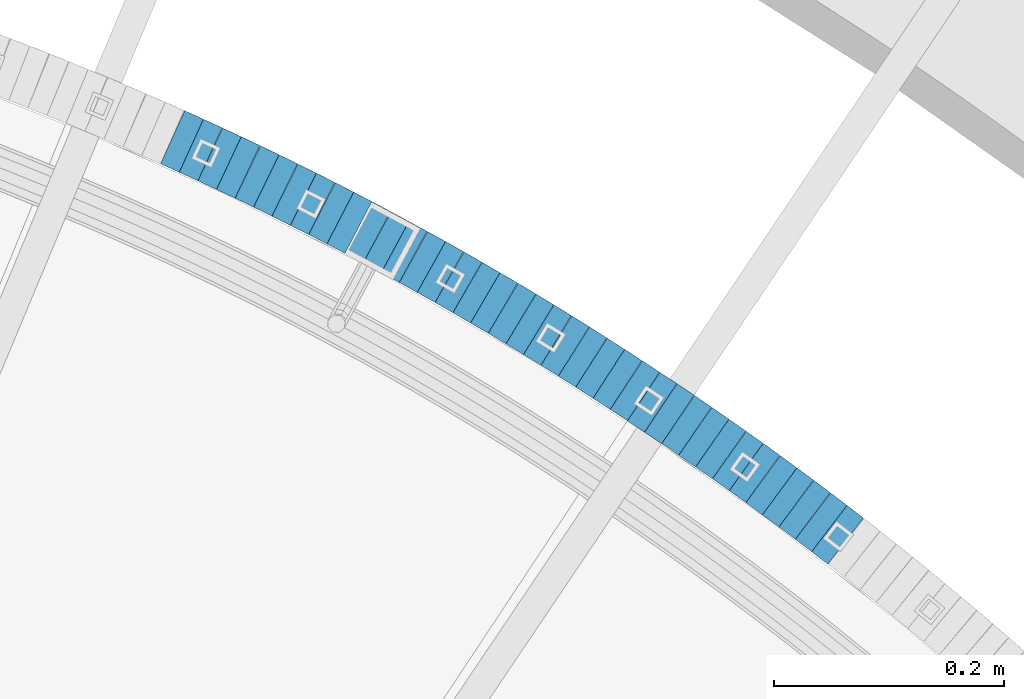
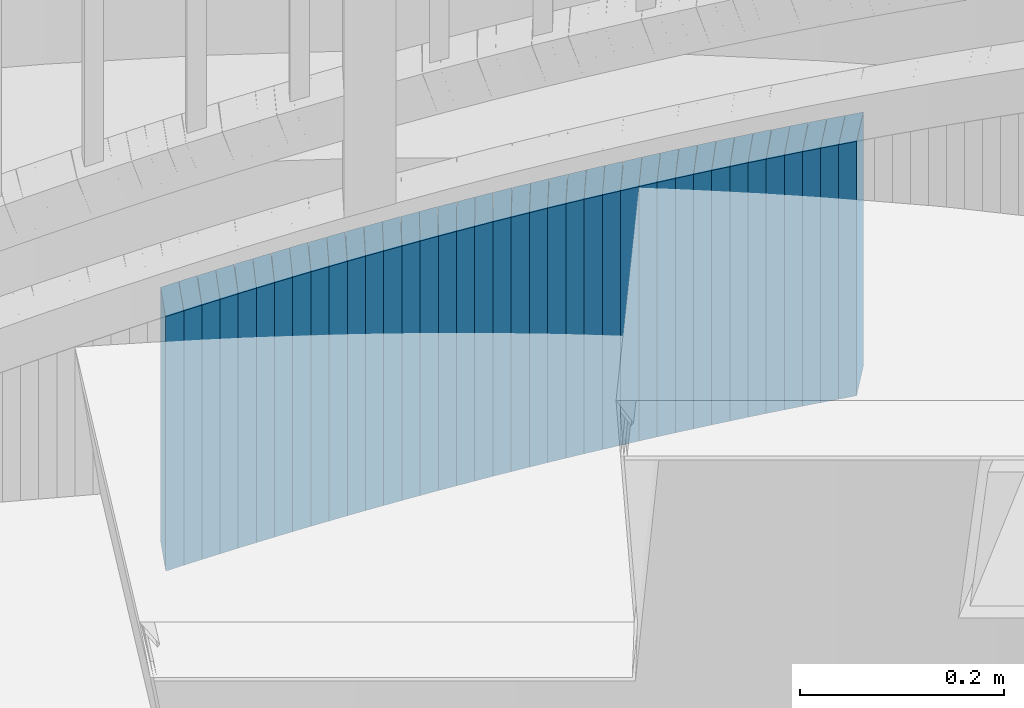
# One storey, part 913 of 975: 38 plates.
"""IFC2X3 building model written with IfcOpenShell, lengths in millimetres."""

from ifc_helpers import new_model, si_unit, frame, origin_with_axes, place, context, subcontext, project, spatial, faceted_brep, material, type_object, element, save


model = new_model("IFC2X3")

# Units and contexts
model_context = context("Model", 3, precision=1e-05, world=origin_with_axes())
body_context = subcontext(model_context, "Body", "Model", "MODEL_VIEW")
ifc_project = project(units=[si_unit("LENGTHUNIT", "METRE", prefix="MILLI"), si_unit("AREAUNIT", "SQUARE_METRE"), si_unit("VOLUMEUNIT", "CUBIC_METRE"), si_unit("MASSUNIT", "GRAM", prefix="KILO"), si_unit("TIMEUNIT", "SECOND"), si_unit("PLANEANGLEUNIT", "RADIAN"), si_unit("SOLIDANGLEUNIT", "STERADIAN"), si_unit("THERMODYNAMICTEMPERATUREUNIT", "DEGREE_CELSIUS"), si_unit("LUMINOUSINTENSITYUNIT", "LUMEN")], contexts=[model_context])

# Site, building, storey
site_placement = place(None, origin_with_axes())
site = spatial("IfcSite", under=ifc_project, at=site_placement, CompositionType="ELEMENT")
building_placement = place(site_placement, origin_with_axes())
building = spatial("IfcBuilding", under=site, at=building_placement, Name="Undefined", CompositionType="ELEMENT")
storey_placement = place(building_placement, origin_with_axes())
storey = spatial("IfcBuildingStorey", under=building, at=storey_placement, Name="Undefined", CompositionType="ELEMENT", Elevation=0.0)

# Plates
ifc_material = material(Name="STEEL/A36")
plate_type = type_object("IfcPlateType", PredefinedType="NOTDEFINED")
plate_1_placement = place(storey_placement, frame((36480.3631997308, 5682.42898795321, 1663.29999999174), z_axis=(0.793246576330856, -0.608900541253968, 0.0), x_axis=(0.0, 0.0, -1.0)))
element("IfcPlate", 1, at=plate_1_placement, inside=storey, type_object=plate_type, material=ifc_material, Name="WALL", context=body_context, shape_type="Brep", body=[
    faceted_brep([(0.0, -25.3999999999724, -1.81898940354586e-11), (-5.80000019073486, -25.3999999999614, 17.8966484070224), (-5.80000019073486, 25.3999999999105, 17.896648406906), (0.0, 25.3999999999869, 1.45519152283669e-11), (299.0, -25.3999999999614, 17.8966484070224), (299.0, 25.3999999999105, 17.896648406906), (304.799987792969, -25.3999999999724, -1.81898940354586e-11), (304.799987792969, 25.3999999999869, 1.45519152283669e-11)], [[[0, 1, 2, 3]], [[1, 4, 5, 2]], [[4, 6, 7, 5]], [[6, 0, 3, 7]], [[5, 7, 3, 2]], [[6, 4, 1, 0]]]),
])
plate_2_placement = place(storey_placement, frame((36466.0734597563, 5693.29755634309, 1657.59999999174), z_axis=(0.795946119300868, -0.605367471185798, -2.1885171008762e-11), x_axis=(0.0, 0.0, -1.0)))
element("IfcPlate", 2, at=plate_2_placement, inside=storey, type_object=plate_type, material=ifc_material, Name="WALL", context=body_context, shape_type="Brep", body=[
    faceted_brep([(0.0, -25.3999999999724, -1.81898940354586e-11), (-5.69999980926514, -25.3999999999614, 17.8370399475461), (-5.69999980926514, 25.4000000000487, 17.8370399475571), (0.0, 25.3999999999869, 1.45519152283669e-11), (299.100006103516, -25.3999999999614, 17.8370399475461), (299.100006103516, 25.4000000000487, 17.8370399475571), (304.799987792969, -25.3999999999724, -1.81898940354586e-11), (304.799987792969, 25.3999999999869, 1.45519152283669e-11)], [[[0, 1, 2, 3]], [[1, 4, 5, 2]], [[4, 6, 7, 5]], [[6, 0, 3, 7]], [[5, 7, 3, 2]], [[6, 4, 1, 0]]]),
])
plate_3_placement = place(storey_placement, frame((36451.6143616831, 5704.11757822177, 1651.89999999174), z_axis=(0.800671390161603, -0.59910376812092, 0.0), x_axis=(0.0, 0.0, -1.0)))
element("IfcPlate", 3, at=plate_3_placement, inside=storey, type_object=plate_type, material=ifc_material, Name="WALL", context=body_context, shape_type="Brep", body=[
    faceted_brep([(0.0, -25.3999999999724, -1.81898940354586e-11), (-5.69999980926514, -25.3999999999687, 17.8619709015074), (-5.69999980926514, 25.4000000000415, 17.8619709015402), (0.0, 25.3999999999869, 1.45519152283669e-11), (299.100006103516, -25.3999999999687, 17.8619709015074), (299.100006103516, 25.4000000000415, 17.8619709015402), (304.799987792969, -25.3999999999724, -1.81898940354586e-11), (304.799987792969, 25.3999999999869, 1.45519152283669e-11)], [[[0, 1, 2, 3]], [[1, 4, 5, 2]], [[4, 6, 7, 5]], [[6, 0, 3, 7]], [[5, 7, 3, 2]], [[6, 4, 1, 0]]]),
])
plate_4_placement = place(storey_placement, frame((36437.0546886573, 5714.83608177046, 1646.09999999174), z_axis=(0.805336883996211, -0.592817428282328, 1.46393176692072e-10), x_axis=(0.0, 0.0, -1.0)))
element("IfcPlate", 4, at=plate_4_placement, inside=storey, type_object=plate_type, material=ifc_material, Name="WALL", context=body_context, shape_type="Brep", body=[
    faceted_brep([(0.0, -25.3999999999724, -1.81898940354586e-11), (-5.80000019073486, -25.4000000000415, 17.8751220702761), (-5.80000019073486, 25.4000000000015, 17.8751220703089), (0.0, 25.3999999999869, 1.45519152283669e-11), (299.0, -25.4000000000415, 17.8751220702761), (299.0, 25.4000000000015, 17.8751220703089), (304.799987792969, -25.3999999999724, -1.81898940354586e-11), (304.799987792969, 25.3999999999869, 1.45519152283669e-11)], [[[0, 1, 2, 3]], [[1, 4, 5, 2]], [[4, 6, 7, 5]], [[6, 0, 3, 7]], [[5, 7, 3, 2]], [[6, 4, 1, 0]]]),
])
plate_5_placement = place(storey_placement, frame((36422.6546886681, 5725.4360817707, 1640.39999999174), z_axis=(0.805336883996211, -0.592817428282328, 1.46393176692072e-10), x_axis=(0.0, 0.0, -1.0)))
element("IfcPlate", 5, at=plate_5_placement, inside=storey, type_object=plate_type, material=ifc_material, Name="WALL", context=body_context, shape_type="Brep", body=[
    faceted_brep([(0.0, -25.3999999999724, -1.81898940354586e-11), (-5.69999980926514, -25.4000000000233, 17.8807163238162), (-5.69999980926514, 25.400000000096, 17.8807163239253), (0.0, 25.3999999999869, 1.45519152283669e-11), (299.100006103516, -25.4000000000233, 17.8807163238162), (299.100006103516, 25.400000000096, 17.8807163239253), (304.799987792969, -25.3999999999724, -1.81898940354586e-11), (304.799987792969, 25.3999999999869, 1.45519152283669e-11)], [[[0, 1, 2, 3]], [[1, 4, 5, 2]], [[4, 6, 7, 5]], [[6, 0, 3, 7]], [[5, 7, 3, 2]], [[6, 4, 1, 0]]]),
])
plate_6_placement = place(storey_placement, frame((36407.9009429559, 5736.02046201806, 1634.69999999174), z_axis=(0.812595949007109, -0.582827439005094, 0.0), x_axis=(0.0, 0.0, -1.0)))
element("IfcPlate", 6, at=plate_6_placement, inside=storey, type_object=plate_type, material=ifc_material, Name="WALL", context=body_context, shape_type="Brep", body=[
    faceted_brep([(0.0, -25.3999999999724, -1.81898940354586e-11), (-5.69999980926514, -25.3999999999614, 17.8370399475461), (-5.69999980926514, 25.4000000000487, 17.8370399475571), (0.0, 25.3999999999869, 1.45519152283669e-11), (299.100006103516, -25.3999999999614, 17.8370399475461), (299.100006103516, 25.4000000000487, 17.8370399475571), (304.799987792969, -25.3999999999724, -1.81898940354586e-11), (304.799987792969, 25.3999999999869, 1.45519152283669e-11)], [[[0, 1, 2, 3]], [[1, 4, 5, 2]], [[4, 6, 7, 5]], [[6, 0, 3, 7]], [[5, 7, 3, 2]], [[6, 4, 1, 0]]]),
])
plate_7_placement = place(storey_placement, frame((36393.2337559001, 5746.4684861224, 1628.89999999174), z_axis=(0.814486661844144, -0.580182279700082, -9.95614755083806e-11), x_axis=(0.0, 0.0, -1.0)))
element("IfcPlate", 7, at=plate_7_placement, inside=storey, type_object=plate_type, material=ifc_material, Name="WALL", context=body_context, shape_type="Brep", body=[
    faceted_brep([(0.0, -25.3999999999724, -1.81898940354586e-11), (-5.80000019073486, -25.3999999998778, 17.9254016876821), (-5.80000019073486, 25.3999999999651, 17.9254016876057), (0.0, 25.3999999999869, 1.45519152283669e-11), (299.0, -25.3999999998778, 17.9254016876821), (299.0, 25.3999999999651, 17.9254016876057), (304.799987792969, -25.3999999999724, -1.81898940354586e-11), (304.799987792969, 25.3999999999869, 1.45519152283669e-11)], [[[0, 1, 2, 3]], [[1, 4, 5, 2]], [[4, 6, 7, 5]], [[6, 0, 3, 7]], [[5, 7, 3, 2]], [[6, 4, 1, 0]]]),
])
plate_8_placement = place(storey_placement, frame((36378.3725652706, 5756.88236545377, 1623.19999999174), z_axis=(0.818970100023311, -0.573836192016335, 0.0), x_axis=(0.0, 0.0, -1.0)))
element("IfcPlate", 8, at=plate_8_placement, inside=storey, type_object=plate_type, material=ifc_material, Name="WALL", context=body_context, shape_type="Brep", body=[
    faceted_brep([(0.0, -25.3999999999724, -1.81898940354586e-11), (-5.69999980926514, -25.4000000000087, 17.9493732452502), (-5.69999980926514, 25.3999999999905, 17.9493732452102), (0.0, 25.3999999999869, 1.45519152283669e-11), (299.100006103516, -25.4000000000087, 17.9493732452502), (299.100006103516, 25.3999999999905, 17.9493732452102), (304.799987792969, -25.3999999999724, -1.81898940354586e-11), (304.799987792969, 25.3999999999869, 1.45519152283669e-11)], [[[0, 1, 2, 3]], [[1, 4, 5, 2]], [[4, 6, 7, 5]], [[6, 0, 3, 7]], [[5, 7, 3, 2]], [[6, 4, 1, 0]]]),
])
plate_9_placement = place(storey_placement, frame((36363.5771973174, 5767.14886300248, 1617.39999999174), z_axis=(0.821588113820829, -0.570081547875681, 0.0), x_axis=(0.0, 0.0, -1.0)))
element("IfcPlate", 9, at=plate_9_placement, inside=storey, type_object=plate_type, material=ifc_material, Name="WALL", context=body_context, shape_type="Brep", body=[
    faceted_brep([(0.0, -25.3999999999724, -1.81898940354586e-11), (-5.80000019073486, -25.4000000000378, 17.8932952880568), (-5.80000019073486, 25.4000000001179, 17.8932952881351), (0.0, 25.3999999999869, 1.45519152283669e-11), (299.0, -25.4000000000378, 17.8932952880568), (299.0, 25.4000000001179, 17.8932952881351), (304.799987792969, -25.3999999999724, -1.81898940354586e-11), (304.799987792969, 25.3999999999869, 1.45519152283669e-11)], [[[0, 1, 2, 3]], [[1, 4, 5, 2]], [[4, 6, 7, 5]], [[6, 0, 3, 7]], [[5, 7, 3, 2]], [[6, 4, 1, 0]]]),
])
plate_10_placement = place(storey_placement, frame((36348.6146774803, 5777.36069935728, 1611.69999999174), z_axis=(0.825991087710894, -0.56368317610354, -8.04351145688995e-11), x_axis=(0.0, 0.0, -1.0)))
element("IfcPlate", 10, at=plate_10_placement, inside=storey, type_object=plate_type, material=ifc_material, Name="WALL", context=body_context, shape_type="Brep", body=[
    faceted_brep([(0.0, -25.3999999999724, -1.81898940354586e-11), (-5.69999980926514, -25.4000000000087, 17.9245643615468), (-5.69999980926514, 25.3999999999687, 17.9245643615541), (0.0, 25.3999999999869, 1.45519152283669e-11), (299.100006103516, -25.4000000000087, 17.9245643615468), (299.100006103516, 25.3999999999687, 17.9245643615541), (304.799987792969, -25.3999999999724, -1.81898940354586e-11), (304.799987792969, 25.3999999999869, 1.45519152283669e-11)], [[[0, 1, 2, 3]], [[1, 4, 5, 2]], [[4, 6, 7, 5]], [[6, 0, 3, 7]], [[5, 7, 3, 2]], [[6, 4, 1, 0]]]),
])
plate_11_placement = place(storey_placement, frame((36333.5517727904, 5787.47094866563, 1605.99999999174), z_axis=(0.830331643827375, -0.557269558884145, 0.0), x_axis=(0.0, 0.0, -1.0)))
element("IfcPlate", 11, at=plate_11_placement, inside=storey, type_object=plate_type, material=ifc_material, Name="WALL", context=body_context, shape_type="Brep", body=[
    faceted_brep([(0.0, -25.3999999999724, -1.81898940354586e-11), (-5.69999980926514, -25.399999999885, 17.9387855530204), (-5.69999980926514, 25.3999999999651, 17.9387855529603), (0.0, 25.3999999999869, 1.45519152283669e-11), (299.100006103516, -25.399999999885, 17.9387855530204), (299.100006103516, 25.3999999999651, 17.9387855529603), (304.799987792969, -25.3999999999724, -1.81898940354586e-11), (304.799987792969, 25.3999999999869, 1.45519152283669e-11)], [[[0, 1, 2, 3]], [[1, 4, 5, 2]], [[4, 6, 7, 5]], [[6, 0, 3, 7]], [[5, 7, 3, 2]], [[6, 4, 1, 0]]]),
])
plate_12_placement = place(storey_placement, frame((36318.5537280806, 5797.4364209695, 1600.19999999174), z_axis=(0.832909293569711, -0.553409530714104, 0.0), x_axis=(0.0, 0.0, -1.0)))
element("IfcPlate", 12, at=plate_12_placement, inside=storey, type_object=plate_type, material=ifc_material, Name="WALL", context=body_context, shape_type="Brep", body=[
    faceted_brep([(0.0, -25.3999999999724, -1.81898940354586e-11), (-5.80000019073486, -25.4000000000378, 17.8932952880568), (-5.80000019073486, 25.4000000001179, 17.8932952881351), (0.0, 25.3999999999869, 1.45519152283669e-11), (299.0, -25.4000000000378, 17.8932952880568), (299.0, 25.4000000001179, 17.8932952881351), (304.799987792969, -25.3999999999724, -1.81898940354586e-11), (304.799987792969, 25.3999999999869, 1.45519152283669e-11)], [[[0, 1, 2, 3]], [[1, 4, 5, 2]], [[4, 6, 7, 5]], [[6, 0, 3, 7]], [[5, 7, 3, 2]], [[6, 4, 1, 0]]]),
])
plate_13_placement = place(storey_placement, frame((36303.4885180764, 5807.3796038471, 1594.39999999174), z_axis=(0.834609406846763, -0.550842207898864, 0.0), x_axis=(0.0, 0.0, -1.0)))
element("IfcPlate", 13, at=plate_13_placement, inside=storey, type_object=plate_type, material=ifc_material, Name="WALL", context=body_context, shape_type="Brep", body=[
    faceted_brep([(0.0, -25.3999999999724, -1.81898940354586e-11), (-5.80000019073486, -25.4000000000051, 17.9724788665662), (-5.80000019073486, 25.4000000000196, 17.9724788666281), (0.0, 25.3999999999869, 1.45519152283669e-11), (299.0, -25.4000000000051, 17.9724788665662), (299.0, 25.4000000000196, 17.9724788666281), (304.799987792969, -25.3999999999724, -1.81898940354586e-11), (304.799987792969, 25.3999999999869, 1.45519152283669e-11)], [[[0, 1, 2, 3]], [[1, 4, 5, 2]], [[4, 6, 7, 5]], [[6, 0, 3, 7]], [[5, 7, 3, 2]], [[6, 4, 1, 0]]]),
])
plate_14_placement = place(storey_placement, frame((36288.2898121581, 5817.20942100874, 1588.69999999174), z_axis=(0.83972031877, -0.543019139851267, 0.0), x_axis=(0.0, 0.0, -1.0)))
element("IfcPlate", 14, at=plate_14_placement, inside=storey, type_object=plate_type, material=ifc_material, Name="WALL", context=body_context, shape_type="Brep", body=[
    faceted_brep([(0.0, -25.3999999999724, -1.81898940354586e-11), (-5.69999980926514, -25.3999999999687, 17.8619709015074), (-5.69999980926514, 25.4000000000415, 17.8619709015402), (0.0, 25.3999999999869, 1.45519152283669e-11), (299.100006103516, -25.3999999999687, 17.8619709015074), (299.100006103516, 25.4000000000415, 17.8619709015402), (304.799987792969, -25.3999999999724, -1.81898940354586e-11), (304.799987792969, 25.3999999999869, 1.45519152283669e-11)], [[[0, 1, 2, 3]], [[1, 4, 5, 2]], [[4, 6, 7, 5]], [[6, 0, 3, 7]], [[5, 7, 3, 2]], [[6, 4, 1, 0]]]),
])
plate_15_placement = place(storey_placement, frame((36273.1252150877, 5826.95105532787, 1582.99999999174), z_axis=(0.84135946512133, -0.540475948077942, 0.0), x_axis=(0.0, 0.0, -1.0)))
element("IfcPlate", 15, at=plate_15_placement, inside=storey, type_object=plate_type, material=ifc_material, Name="WALL", context=body_context, shape_type="Brep", body=[
    faceted_brep([(0.0, -25.3999999999724, -1.81898940354586e-11), (-5.69999980926514, -25.4000000000087, 17.9493732452502), (-5.69999980926514, 25.3999999999905, 17.9493732452102), (0.0, 25.3999999999869, 1.45519152283669e-11), (299.100006103516, -25.4000000000087, 17.9493732452502), (299.100006103516, 25.3999999999905, 17.9493732452102), (304.799987792969, -25.3999999999724, -1.81898940354586e-11), (304.799987792969, 25.3999999999869, 1.45519152283669e-11)], [[[0, 1, 2, 3]], [[1, 4, 5, 2]], [[4, 6, 7, 5]], [[6, 0, 3, 7]], [[5, 7, 3, 2]], [[6, 4, 1, 0]]]),
])
plate_16_placement = place(storey_placement, frame((36257.9245770752, 5836.61536984319, 1577.19999999174), z_axis=(0.843891532718926, -0.536513821821304, 0.0), x_axis=(0.0, 0.0, -1.0)))
element("IfcPlate", 16, at=plate_16_placement, inside=storey, type_object=plate_type, material=ifc_material, Name="WALL", context=body_context, shape_type="Brep", body=[
    faceted_brep([(0.0, -25.3999999999724, -1.81898940354586e-11), (-5.80000019073486, -25.4000000000378, 17.8932952880568), (-5.80000019073486, 25.4000000001179, 17.8932952881351), (0.0, 25.3999999999869, 1.45519152283669e-11), (299.0, -25.4000000000378, 17.8932952880568), (299.0, 25.4000000001179, 17.8932952881351), (304.799987792969, -25.3999999999724, -1.81898940354586e-11), (304.799987792969, 25.3999999999869, 1.45519152283669e-11)], [[[0, 1, 2, 3]], [[1, 4, 5, 2]], [[4, 6, 7, 5]], [[6, 0, 3, 7]], [[5, 7, 3, 2]], [[6, 4, 1, 0]]]),
])
plate_17_placement = place(storey_placement, frame((36242.5590990763, 5846.21968183435, 1571.49999999174), z_axis=(0.847998304005088, -0.529998940003181, 0.0), x_axis=(0.0, 0.0, -1.0)))
element("IfcPlate", 17, at=plate_17_placement, inside=storey, type_object=plate_type, material=ifc_material, Name="WALL", context=body_context, shape_type="Brep", body=[
    faceted_brep([(0.0, -25.3999999999724, -1.81898940354586e-11), (-5.69999980926514, -25.4000000000087, 17.9245643615468), (-5.69999980926514, 25.3999999999687, 17.9245643615541), (0.0, 25.3999999999869, 1.45519152283669e-11), (299.100006103516, -25.4000000000087, 17.9245643615468), (299.100006103516, 25.3999999999687, 17.9245643615541), (304.799987792969, -25.3999999999724, -1.81898940354586e-11), (304.799987792969, 25.3999999999869, 1.45519152283669e-11)], [[[0, 1, 2, 3]], [[1, 4, 5, 2]], [[4, 6, 7, 5]], [[6, 0, 3, 7]], [[5, 7, 3, 2]], [[6, 4, 1, 0]]]),
])
plate_18_placement = place(storey_placement, frame((36227.1534858187, 5855.64683342129, 1565.69999999174), z_axis=(0.853004271914828, -0.521903929947891, 0.0), x_axis=(0.0, 0.0, -1.0)))
element("IfcPlate", 18, at=plate_18_placement, inside=storey, type_object=plate_type, material=ifc_material, Name="WALL", context=body_context, shape_type="Brep", body=[
    faceted_brep([(0.0, -25.3999999999724, -1.81898940354586e-11), (-5.80000019073486, -25.400000000016, 17.8193721771022), (-5.80000019073486, 25.4000000001179, 17.8193721772113), (0.0, 25.3999999999869, 1.45519152283669e-11), (299.0, -25.400000000016, 17.8193721771022), (299.0, 25.4000000001179, 17.8193721772113), (304.799987792969, -25.3999999999724, -1.81898940354586e-11), (304.799987792969, 25.3999999999869, 1.45519152283669e-11)], [[[0, 1, 2, 3]], [[1, 4, 5, 2]], [[4, 6, 7, 5]], [[6, 0, 3, 7]], [[5, 7, 3, 2]], [[6, 4, 1, 0]]]),
])
plate_19_placement = place(storey_placement, frame((36211.7902745677, 5864.98538222128, 1559.99999999174), z_axis=(0.854521941236345, -0.519415298143661, 0.0), x_axis=(0.0, 0.0, -1.0)))
element("IfcPlate", 19, at=plate_19_placement, inside=storey, type_object=plate_type, material=ifc_material, Name="WALL", context=body_context, shape_type="Brep", body=[
    faceted_brep([(0.0, -25.3999999999724, -1.81898940354586e-11), (-5.69999980926514, -25.3999999999578, 17.9047489166387), (-5.69999980926514, 25.3999999999069, 17.9047489165732), (0.0, 25.3999999999869, 1.45519152283669e-11), (299.100006103516, -25.3999999999578, 17.9047489166387), (299.100006103516, 25.3999999999069, 17.9047489165732), (304.799987792969, -25.3999999999724, -1.81898940354586e-11), (304.799987792969, 25.3999999999869, 1.45519152283669e-11)], [[[0, 1, 2, 3]], [[1, 4, 5, 2]], [[4, 6, 7, 5]], [[6, 0, 3, 7]], [[5, 7, 3, 2]], [[6, 4, 1, 0]]]),
])
plate_20_placement = place(storey_placement, frame((36196.2236493891, 5874.28579235175, 1554.29999999174), z_axis=(0.858475096018804, -0.512855252011233, 0.0), x_axis=(0.0, 0.0, -1.0)))
element("IfcPlate", 20, at=plate_20_placement, inside=storey, type_object=plate_type, material=ifc_material, Name="WALL", context=body_context, shape_type="Brep", body=[
    faceted_brep([(0.0, -25.3999999999724, -1.81898940354586e-11), (-5.69999980926514, -25.399999999885, 17.9387855530204), (-5.69999980926514, 25.3999999999651, 17.9387855529603), (0.0, 25.3999999999869, 1.45519152283669e-11), (299.100006103516, -25.399999999885, 17.9387855530204), (299.100006103516, 25.3999999999651, 17.9387855529603), (304.799987792969, -25.3999999999724, -1.81898940354586e-11), (304.799987792969, 25.3999999999869, 1.45519152283669e-11)], [[[0, 1, 2, 3]], [[1, 4, 5, 2]], [[4, 6, 7, 5]], [[6, 0, 3, 7]], [[5, 7, 3, 2]], [[6, 4, 1, 0]]]),
])
plate_21_placement = place(storey_placement, frame((36180.6131536631, 5883.41017229435, 1548.49999999174), z_axis=(0.863371944049593, -0.504568019426546, 2.19373305299087e-10), x_axis=(0.0, 0.0, -1.0)))
element("IfcPlate", 21, at=plate_21_placement, inside=storey, type_object=plate_type, material=ifc_material, Name="WALL", context=body_context, shape_type="Brep", body=[
    faceted_brep([(0.0, -25.3999999999724, -1.81898940354586e-11), (-5.80000019073486, -25.3999999999578, 17.8370399475461), (-5.80000019073486, 25.4000000000524, 17.8370399475607), (0.0, 25.3999999999869, 1.45519152283669e-11), (299.0, -25.3999999999578, 17.8370399475461), (299.0, 25.4000000000524, 17.8370399475607), (304.799987792969, -25.3999999999724, -1.81898940354586e-11), (304.799987792969, 25.3999999999869, 1.45519152283669e-11)], [[[0, 1, 2, 3]], [[1, 4, 5, 2]], [[4, 6, 7, 5]], [[6, 0, 3, 7]], [[5, 7, 3, 2]], [[6, 4, 1, 0]]]),
])
plate_22_placement = place(storey_placement, frame((36165.2131536523, 5892.41017229264, 1542.79999999174), z_axis=(0.863371944049593, -0.504568019426546, 2.19373305299087e-10), x_axis=(0.0, 0.0, -1.0)))
element("IfcPlate", 22, at=plate_22_placement, inside=storey, type_object=plate_type, material=ifc_material, Name="WALL", context=body_context, shape_type="Brep", body=[
    faceted_brep([(0.0, -25.3999999999724, -1.81898940354586e-11), (-5.69999980926514, -25.3999999999614, 17.8370399475461), (-5.69999980926514, 25.4000000000487, 17.8370399475571), (0.0, 25.3999999999869, 1.45519152283669e-11), (299.100006103516, -25.3999999999614, 17.8370399475461), (299.100006103516, 25.4000000000487, 17.8370399475571), (304.799987792969, -25.3999999999724, -1.81898940354586e-11), (304.799987792969, 25.3999999999869, 1.45519152283669e-11)], [[[0, 1, 2, 3]], [[1, 4, 5, 2]], [[4, 6, 7, 5]], [[6, 0, 3, 7]], [[5, 7, 3, 2]], [[6, 4, 1, 0]]]),
])
plate_23_placement = place(storey_placement, frame((36149.5449402364, 5901.4076171817, 1537.09999999174), z_axis=(0.86720835715133, -0.497945444086892, 0.0), x_axis=(0.0, 0.0, -1.0)))
element("IfcPlate", 23, at=plate_23_placement, inside=storey, type_object=plate_type, material=ifc_material, Name="WALL", context=body_context, shape_type="Brep", body=[
    faceted_brep([(0.0, -25.3999999999724, -1.81898940354586e-11), (-5.69999980926514, -25.4000000000524, 17.8734436034756), (-5.69999980926514, 25.4000000000888, 17.8734436035884), (0.0, 25.3999999999869, 1.45519152283669e-11), (299.100006103516, -25.4000000000524, 17.8734436034756), (299.100006103516, 25.4000000000888, 17.8734436035884), (304.799987792969, -25.3999999999724, -1.81898940354586e-11), (304.799987792969, 25.3999999999869, 1.45519152283669e-11)], [[[0, 1, 2, 3]], [[1, 4, 5, 2]], [[4, 6, 7, 5]], [[6, 0, 3, 7]], [[5, 7, 3, 2]], [[6, 4, 1, 0]]]),
])
plate_24_placement = place(storey_placement, frame((36133.6686611532, 5910.26396730928, 1531.29999999174), z_axis=(0.873363874286145, -0.487068314604733, 1.57350356744245e-10), x_axis=(0.0, 0.0, -1.0)))
element("IfcPlate", 24, at=plate_24_placement, inside=storey, type_object=plate_type, material=ifc_material, Name="WALL", context=body_context, shape_type="Brep", body=[
    faceted_brep([(0.0, -25.3999999999724, -1.81898940354586e-11), (-5.80000019073486, -25.3999999999978, 17.8619709014965), (-5.80000019073486, 25.4000000000524, 17.8619709015475), (0.0, 25.3999999999869, 1.45519152283669e-11), (299.0, -25.3999999999978, 17.8619709014965), (299.0, 25.4000000000524, 17.8619709015475), (304.799987792969, -25.3999999999724, -1.81898940354586e-11), (304.799987792969, 25.3999999999869, 1.45519152283669e-11)], [[[0, 1, 2, 3]], [[1, 4, 5, 2]], [[4, 6, 7, 5]], [[6, 0, 3, 7]], [[5, 7, 3, 2]], [[6, 4, 1, 0]]]),
])
plate_25_placement = place(storey_placement, frame((36118.0686611482, 5918.96396730841, 1525.59999999174), z_axis=(0.873363874286145, -0.487068314604733, 1.57350356744245e-10), x_axis=(0.0, 0.0, -1.0)))
element("IfcPlate", 25, at=plate_25_placement, inside=storey, type_object=plate_type, material=ifc_material, Name="WALL", context=body_context, shape_type="Brep", body=[
    faceted_brep([(0.0, -25.3999999999724, -1.81898940354586e-11), (-5.69999980926514, -25.3999999999687, 17.8619709015074), (-5.69999980926514, 25.4000000000415, 17.8619709015402), (0.0, 25.3999999999869, 1.45519152283669e-11), (299.100006103516, -25.3999999999687, 17.8619709015074), (299.100006103516, 25.4000000000415, 17.8619709015402), (304.799987792969, -25.3999999999724, -1.81898940354586e-11), (304.799987792969, 25.3999999999869, 1.45519152283669e-11)], [[[0, 1, 2, 3]], [[1, 4, 5, 2]], [[4, 6, 7, 5]], [[6, 0, 3, 7]], [[5, 7, 3, 2]], [[6, 4, 1, 0]]]),
])
for number, where, z_axis, x_axis, name in (
    (26, (36102.0901344495, 5927.61702296236, 1519.89999999174), (0.879389687131047, -0.476102697080744, -2.74968670055387e-12), (0.0, 0.0, -1.0), "WALL"),
    (27, (36086.3901344469, 5936.11702296326, 1514.19999999174), (0.879389687131047, -0.476102697080744, -2.74968670055387e-12), (0.0, 0.0, -1.0), "WALL"),
):
    element("IfcPlate", number, at=place(storey_placement, frame(where, z_axis=z_axis, x_axis=x_axis)), inside=storey, type_object=plate_type, material=ifc_material, Name=name, context=body_context, shape_type="Brep", body=[
        faceted_brep([(0.0, -25.3999999999724, -1.81898940354586e-11), (-5.69999980926514, -25.3999999999578, 17.853290557905), (-5.69999980926514, 25.4000000000124, 17.8532905578759), (0.0, 25.3999999999869, 1.45519152283669e-11), (299.100006103516, -25.3999999999578, 17.853290557905), (299.100006103516, 25.4000000000124, 17.8532905578759), (304.799987792969, -25.3999999999724, -1.81898940354586e-11), (304.799987792969, 25.3999999999869, 1.45519152283669e-11)], [[[0, 1, 2, 3]], [[1, 4, 5, 2]], [[4, 6, 7, 5]], [[6, 0, 3, 7]], [[5, 7, 3, 2]], [[6, 4, 1, 0]]]),
    ])
plate_26_placement = place(storey_placement, frame((36070.420587025, 5944.60798744199, 1508.39999999174), z_axis=(0.882970965834168, -0.469427601972739, 3.48595676769037e-11), x_axis=(0.0, 0.0, -1.0)))
element("IfcPlate", 28, at=plate_26_placement, inside=storey, type_object=plate_type, material=ifc_material, Name="WALL", context=body_context, shape_type="Brep", body=[
    faceted_brep([(0.0, -25.3999999999724, -1.81898940354586e-11), (-5.80000019073486, -25.4000000000378, 17.8932952880568), (-5.80000019073486, 25.4000000001179, 17.8932952881351), (0.0, 25.3999999999869, 1.45519152283669e-11), (299.0, -25.4000000000378, 17.8932952880568), (299.0, 25.4000000001179, 17.8932952881351), (304.799987792969, -25.3999999999724, -1.81898940354586e-11), (304.799987792969, 25.3999999999869, 1.45519152283669e-11)], [[[0, 1, 2, 3]], [[1, 4, 5, 2]], [[4, 6, 7, 5]], [[6, 0, 3, 7]], [[5, 7, 3, 2]], [[6, 4, 1, 0]]]),
])
plate_27_placement = place(storey_placement, frame((36054.3975109779, 5952.92516927468, 1502.69999999174), z_axis=(0.887584423843917, -0.460645080891636, -1.58238435687963e-11), x_axis=(0.0, 0.0, -1.0)))
element("IfcPlate", 29, at=plate_27_placement, inside=storey, type_object=plate_type, material=ifc_material, Name="WALL", context=body_context, shape_type="Brep", body=[
    faceted_brep([(0.0, -25.3999999999724, -1.81898940354586e-11), (-5.69999980926514, -25.4000000000378, 17.8044929504049), (-5.69999980926514, 25.4000000000233, 17.8044929504613), (0.0, 25.3999999999869, 1.45519152283669e-11), (299.100006103516, -25.4000000000378, 17.8044929504049), (299.100006103516, 25.4000000000233, 17.8044929504613), (304.799987792969, -25.3999999999724, -1.81898940354586e-11), (304.799987792969, 25.3999999999869, 1.45519152283669e-11)], [[[0, 1, 2, 3]], [[1, 4, 5, 2]], [[4, 6, 7, 5]], [[6, 0, 3, 7]], [[5, 7, 3, 2]], [[6, 4, 1, 0]]]),
])
for number, where, z_axis, x_axis, name in (
    (30, (36038.439422383, 5961.15522166281, 1496.99999999174), (0.88876758866203, -0.458358127825701, 0.0), (0.0, 0.0, -1.0), "WALL"),
    (31, (36022.1563512515, 5969.29897556564, 1491.29999999174), (0.894427190945564, -0.447213595608663, -1.9893241187674e-10), (0.0, 0.0, -1.0), "WALL"),
):
    element("IfcPlate", number, at=place(storey_placement, frame(where, z_axis=z_axis, x_axis=x_axis)), inside=storey, type_object=plate_type, material=ifc_material, Name=name, context=body_context, shape_type="Brep", body=[
        faceted_brep([(0.0, -25.3999999999724, -1.81898940354586e-11), (-5.69999980926514, -25.4000000000087, 17.8910598754701), (-5.69999980926514, 25.4000000000087, 17.8910598755028), (0.0, 25.3999999999869, 1.45519152283669e-11), (299.100006103516, -25.4000000000087, 17.8910598754701), (299.100006103516, 25.4000000000087, 17.8910598755028), (304.799987792969, -25.3999999999724, -1.81898940354586e-11), (304.799987792969, 25.3999999999869, 1.45519152283669e-11)], [[[0, 1, 2, 3]], [[1, 4, 5, 2]], [[4, 6, 7, 5]], [[6, 0, 3, 7]], [[5, 7, 3, 2]], [[6, 4, 1, 0]]]),
    ])
plate_28_placement = place(storey_placement, frame((36006.1563512512, 5977.29897556581, 1485.49999999174), z_axis=(0.894427190945564, -0.447213595608663, -1.9893241187674e-10), x_axis=(0.0, 0.0, -1.0)))
element("IfcPlate", 32, at=plate_28_placement, inside=storey, type_object=plate_type, material=ifc_material, Name="WALL", context=body_context, shape_type="Brep", body=[
    faceted_brep([(0.0, -25.3999999999724, -1.81898940354586e-11), (-5.80000019073486, -25.4000000000378, 17.8932952880568), (-5.80000019073486, 25.4000000001179, 17.8932952881351), (0.0, 25.3999999999869, 1.45519152283669e-11), (299.0, -25.4000000000378, 17.8932952880568), (299.0, 25.4000000001179, 17.8932952881351), (304.799987792969, -25.3999999999724, -1.81898940354586e-11), (304.799987792969, 25.3999999999869, 1.45519152283669e-11)], [[[0, 1, 2, 3]], [[1, 4, 5, 2]], [[4, 6, 7, 5]], [[6, 0, 3, 7]], [[5, 7, 3, 2]], [[6, 4, 1, 0]]]),
])
plate_29_placement = place(storey_placement, frame((35989.9274629999, 5985.21198558455, 1479.79999999174), z_axis=(0.898876404474688, -0.43820224723141, 0.0), x_axis=(0.0, 0.0, -1.0)))
element("IfcPlate", 33, at=plate_29_placement, inside=storey, type_object=plate_type, material=ifc_material, Name="WALL", context=body_context, shape_type="Brep", body=[
    faceted_brep([(0.0, -25.3999999999724, -1.81898940354586e-11), (-5.69999980926514, -25.4000000000378, 17.8044929504049), (-5.69999980926514, 25.4000000000233, 17.8044929504613), (0.0, 25.3999999999869, 1.45519152283669e-11), (299.100006103516, -25.4000000000378, 17.8044929504049), (299.100006103516, 25.4000000000233, 17.8044929504613), (304.799987792969, -25.3999999999724, -1.81898940354586e-11), (304.799987792969, 25.3999999999869, 1.45519152283669e-11)], [[[0, 1, 2, 3]], [[1, 4, 5, 2]], [[4, 6, 7, 5]], [[6, 0, 3, 7]], [[5, 7, 3, 2]], [[6, 4, 1, 0]]]),
])
plate_30_placement = place(storey_placement, frame((35973.7715054573, 5993.03918011911, 1474.09999999174), z_axis=(0.899947055462652, -0.435999194224143, 0.0), x_axis=(0.0, 0.0, -1.0)))
element("IfcPlate", 34, at=plate_30_placement, inside=storey, type_object=plate_type, material=ifc_material, Name="WALL", context=body_context, shape_type="Brep", body=[
    faceted_brep([(0.0, -25.3999999999724, -1.81898940354586e-11), (-5.69999980926514, -25.4000000000087, 17.8910598754701), (-5.69999980926514, 25.4000000000087, 17.8910598755028), (0.0, 25.3999999999869, 1.45519152283669e-11), (299.100006103516, -25.4000000000087, 17.8910598754701), (299.100006103516, 25.4000000000087, 17.8910598755028), (304.799987792969, -25.3999999999724, -1.81898940354586e-11), (304.799987792969, 25.3999999999869, 1.45519152283669e-11)], [[[0, 1, 2, 3]], [[1, 4, 5, 2]], [[4, 6, 7, 5]], [[6, 0, 3, 7]], [[5, 7, 3, 2]], [[6, 4, 1, 0]]]),
])
plate_31_placement = place(storey_placement, frame((35957.2850192856, 6000.77577130664, 1468.29999999174), z_axis=(0.905324661250481, -0.42472021111751, 0.0), x_axis=(0.0, 0.0, -1.0)))
element("IfcPlate", 35, at=plate_31_placement, inside=storey, type_object=plate_type, material=ifc_material, Name="WALL", context=body_context, shape_type="Brep", body=[
    faceted_brep([(0.0, -25.3999999999724, -1.81898940354586e-11), (-5.80000019073486, -25.4000000000378, 17.8932952880568), (-5.80000019073486, 25.4000000001179, 17.8932952881351), (0.0, 25.3999999999869, 1.45519152283669e-11), (299.0, -25.4000000000378, 17.8932952880568), (299.0, 25.4000000001179, 17.8932952881351), (304.799987792969, -25.3999999999724, -1.81898940354586e-11), (304.799987792969, 25.3999999999869, 1.45519152283669e-11)], [[[0, 1, 2, 3]], [[1, 4, 5, 2]], [[4, 6, 7, 5]], [[6, 0, 3, 7]], [[5, 7, 3, 2]], [[6, 4, 1, 0]]]),
])
plate_32_placement = place(storey_placement, frame((35941.0850192848, 6008.3757713072, 1462.59999999174), z_axis=(0.905324661250481, -0.42472021111751, 0.0), x_axis=(0.0, 0.0, -1.0)))
element("IfcPlate", 36, at=plate_32_placement, inside=storey, type_object=plate_type, material=ifc_material, Name="WALL", context=body_context, shape_type="Brep", body=[
    faceted_brep([(0.0, -25.3999999999724, -1.81898940354586e-11), (-5.69999980926514, -25.4000000000087, 17.8910598754701), (-5.69999980926514, 25.4000000000087, 17.8910598755028), (0.0, 25.3999999999869, 1.45519152283669e-11), (299.100006103516, -25.4000000000087, 17.8910598754701), (299.100006103516, 25.4000000000087, 17.8910598755028), (304.799987792969, -25.3999999999724, -1.81898940354586e-11), (304.799987792969, 25.3999999999869, 1.45519152283669e-11)], [[[0, 1, 2, 3]], [[1, 4, 5, 2]], [[4, 6, 7, 5]], [[6, 0, 3, 7]], [[5, 7, 3, 2]], [[6, 4, 1, 0]]]),
])
plate_33_placement = place(storey_placement, frame((35924.650682614, 6015.88425710315, 1456.89999999174), z_axis=(0.909595755713219, -0.415494357589244, -1.62878222909057e-10), x_axis=(0.0, 0.0, -1.0)))
element("IfcPlate", 37, at=plate_33_placement, inside=storey, type_object=plate_type, material=ifc_material, Name="WALL", context=body_context, shape_type="Brep", body=[
    faceted_brep([(0.0, -25.3999999999724, -1.81898940354586e-11), (-5.69999980926514, -25.4000000001106, 17.8134784697704), (-5.69999980926514, 25.4000000000306, 17.8134784698614), (0.0, 25.3999999999869, 1.45519152283669e-11), (299.100006103516, -25.4000000001106, 17.8134784697704), (299.100006103516, 25.4000000000306, 17.8134784698614), (304.799987792969, -25.3999999999724, -1.81898940354586e-11), (304.799987792969, 25.3999999999869, 1.45519152283669e-11)], [[[0, 1, 2, 3]], [[1, 4, 5, 2]], [[4, 6, 7, 5]], [[6, 0, 3, 7]], [[5, 7, 3, 2]], [[6, 4, 1, 0]]]),
])
plate_34_placement = place(storey_placement, frame((35908.2970292029, 6023.30869023199, 1451.09999999174), z_axis=(0.910557689794828, -0.413382018906854, 0.0), x_axis=(0.0, 0.0, -1.0)))
element("IfcPlate", 38, at=plate_34_placement, inside=storey, type_object=plate_type, material=ifc_material, Name="WALL", context=body_context, shape_type="Brep", body=[
    faceted_brep([(0.0, -25.3999999999724, -1.81898940354586e-11), (-5.80000019073486, -25.3999999999614, 17.8966484070224), (-5.80000019073486, 25.3999999999105, 17.896648406906), (0.0, 25.3999999999869, 1.45519152283669e-11), (299.0, -25.3999999999614, 17.8966484070224), (299.0, 25.3999999999105, 17.896648406906), (304.799987792969, -25.3999999999724, -1.81898940354586e-11), (304.799987792969, 25.3999999999869, 1.45519152283669e-11)], [[[0, 1, 2, 3]], [[1, 4, 5, 2]], [[4, 6, 7, 5]], [[6, 0, 3, 7]], [[5, 7, 3, 2]], [[6, 4, 1, 0]]]),
])

save(model, "model.ifc")
